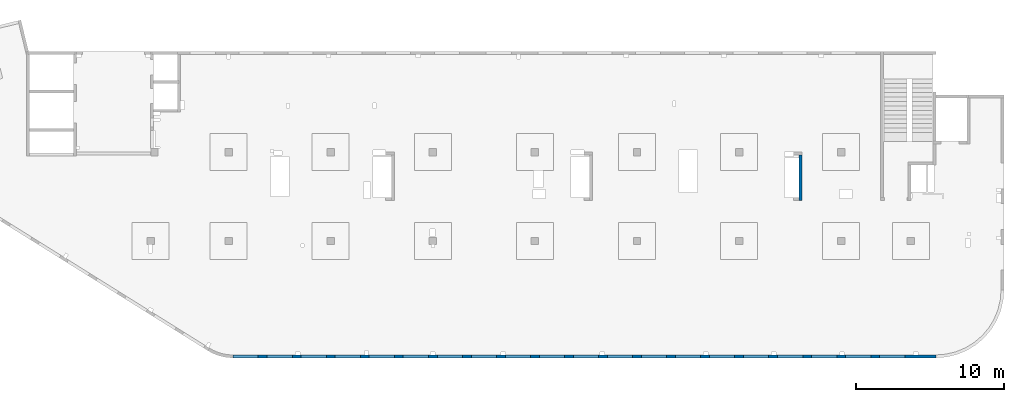
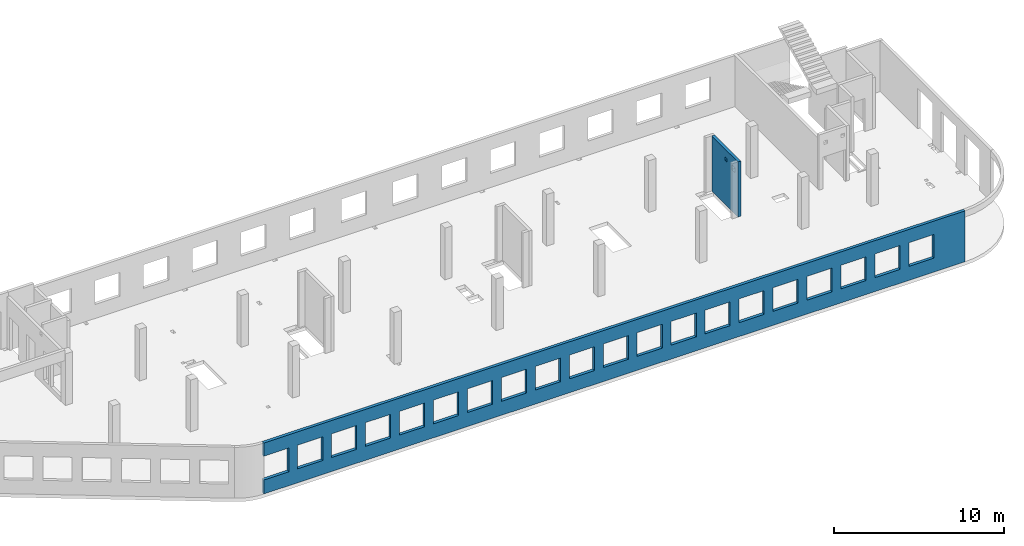
# One storey, part 6 of 7: 2 walls, 22 openings.
"""IFC4 building model written with IfcOpenShell, lengths in millimetres."""

from ifc_helpers import new_model, entity, si_unit, converted_unit, derived_unit, direction, frame, origin, place, context, subcontext, project, spatial, indexed_curve, outline, extrude, polygons, material, type_object, element, save


model = new_model("IFC4")

# Units and contexts
model_context = context("Model", 3, precision=0.01, world=origin(), true_north=direction((6.12303176911189e-17, 1.0)))
plan_context = context("Plan", 3, precision=0.01, world=origin(), true_north=direction((6.12303176911189e-17, 1.0)))
body_context = subcontext(model_context, "Body", "Model", "MODEL_VIEW")
ifc_project = project(units=[si_unit("LENGTHUNIT", "METRE", prefix="MILLI"), si_unit("AREAUNIT", "SQUARE_METRE"), si_unit("VOLUMEUNIT", "CUBIC_METRE"), converted_unit("PLANEANGLEUNIT", "DEGREE", entity("IfcRatioMeasure", 0.0174532925199433), si_unit("PLANEANGLEUNIT", "RADIAN"), dimensions=[0, 0, 0, 0, 0, 0, 0]), si_unit("MASSUNIT", "GRAM", prefix="KILO"), derived_unit("MASSDENSITYUNIT", [(si_unit("MASSUNIT", "GRAM", prefix="KILO"), 1), (si_unit("LENGTHUNIT", "METRE"), -3)]), derived_unit("MOMENTOFINERTIAUNIT", [(si_unit("LENGTHUNIT", "METRE"), 4)]), si_unit("TIMEUNIT", "SECOND"), si_unit("FREQUENCYUNIT", "HERTZ"), si_unit("THERMODYNAMICTEMPERATUREUNIT", "DEGREE_CELSIUS"), derived_unit("THERMALTRANSMITTANCEUNIT", [(si_unit("MASSUNIT", "GRAM", prefix="KILO"), 1), (si_unit("THERMODYNAMICTEMPERATUREUNIT", "KELVIN"), -1), (si_unit("TIMEUNIT", "SECOND"), -3)]), derived_unit("VOLUMETRICFLOWRATEUNIT", [(si_unit("LENGTHUNIT", "METRE"), 3), (si_unit("TIMEUNIT", "SECOND"), -1)]), derived_unit("MASSFLOWRATEUNIT", [(si_unit("MASSUNIT", "GRAM", prefix="KILO"), 1), (si_unit("TIMEUNIT", "SECOND"), -1)]), derived_unit("ROTATIONALFREQUENCYUNIT", [(si_unit("TIMEUNIT", "SECOND"), -1)]), si_unit("ELECTRICCURRENTUNIT", "AMPERE"), si_unit("ELECTRICVOLTAGEUNIT", "VOLT"), si_unit("POWERUNIT", "WATT"), si_unit("FORCEUNIT", "NEWTON", prefix="KILO"), si_unit("ILLUMINANCEUNIT", "LUX"), si_unit("LUMINOUSFLUXUNIT", "LUMEN"), si_unit("LUMINOUSINTENSITYUNIT", "CANDELA"), derived_unit("USERDEFINED", [(si_unit("MASSUNIT", "GRAM", prefix="KILO"), -1), (si_unit("LENGTHUNIT", "METRE"), -2), (si_unit("TIMEUNIT", "SECOND"), 3), (si_unit("LUMINOUSFLUXUNIT", "LUMEN"), 1)]), derived_unit("LINEARVELOCITYUNIT", [(si_unit("LENGTHUNIT", "METRE"), 1), (si_unit("TIMEUNIT", "SECOND"), -1)]), si_unit("PRESSUREUNIT", "PASCAL"), derived_unit("USERDEFINED", [(si_unit("LENGTHUNIT", "METRE"), -2), (si_unit("MASSUNIT", "GRAM", prefix="KILO"), 1), (si_unit("TIMEUNIT", "SECOND"), -2)]), derived_unit("LINEARFORCEUNIT", [(si_unit("MASSUNIT", "GRAM", prefix="KILO"), 1), (si_unit("LENGTHUNIT", "METRE"), 1), (si_unit("TIMEUNIT", "SECOND"), -2), (si_unit("LENGTHUNIT", "METRE"), -1)]), derived_unit("PLANARFORCEUNIT", [(si_unit("MASSUNIT", "GRAM", prefix="KILO"), 1), (si_unit("LENGTHUNIT", "METRE"), 1), (si_unit("TIMEUNIT", "SECOND"), -2), (si_unit("LENGTHUNIT", "METRE"), -2)])], contexts=[model_context, plan_context])

# Site, building, storey
site_placement = place(None, origin())
site = spatial("IfcSite", under=ifc_project, at=site_placement, CompositionType="ELEMENT")
building_placement = place(site_placement, origin())
building = spatial("IfcBuilding", under=site, at=building_placement, CompositionType="ELEMENT")
storey_placement = place(building_placement, frame((0.0, 0.0, 12000.0)))
storey = spatial("IfcBuildingStorey", under=building, at=storey_placement, CompositionType="ELEMENT", Elevation=12000.0)

# Wall, openings
ifc_material = material()
wall_type = type_object("IfcWallType", PredefinedType="STANDARD")
wall_1_placement = place(storey_placement, frame((68970.0002685547, -99.9999557734324, -150.0), z_axis=(0.0, 0.0, 1.0), x_axis=(-1.0, 0.0, 0.0)))
wall_1 = element("IfcWall", 1, at=wall_1_placement, inside=storey, type_object=wall_type, material=ifc_material, PredefinedType="NOTDEFINED", context=body_context, shape_type="Tessellation", body=[
    polygons([(8.66293717728731e-12, -100.0, 0.0), (47500.0, -100.0, 0.0), (47500.0, -100.0, 1000.00000000001), (45800.0, -100.000000000321, 1000.00000000001), (45800.0, -100.000000000321, 2699.99999999999), (47500.0, -100.0, 2699.99999999999), (47500.0, -100.0, 3650.0), (8.66293717728731e-12, -100.0, 3650.0), (1.42900165493394e-19, -100.0, 3200.0), (43500.0, -100.000000000321, 2700.0), (45200.0, -100.000000000321, 2700.0), (45200.0, -100.000000000321, 1000.00000000001), (43500.0, -100.000000000321, 1000.00000000001), (41200.0, -100.000000000321, 2700.0), (42900.0, -100.000000000321, 2700.0), (42900.0, -100.000000000321, 1000.00000000001), (41200.0, -100.000000000321, 1000.00000000001), (38900.0, -100.000000000321, 2700.0), (40600.0, -100.000000000321, 2700.0), (40600.0, -100.000000000321, 1000.00000000001), (38900.0, -100.000000000321, 1000.00000000001), (36600.0, -100.000000000321, 2700.0), (38300.0, -100.000000000321, 2700.0), (38300.0, -100.000000000321, 1000.00000000001), (36600.0, -100.000000000321, 1000.00000000001), (34300.0, -100.000000000321, 2700.0), (36000.0, -100.000000000321, 2700.0), (36000.0, -100.000000000321, 1000.00000000001), (34300.0, -100.000000000321, 1000.00000000001), (32000.0, -100.000000000321, 2700.0), (33700.0, -100.000000000321, 2700.0), (33700.0, -100.000000000321, 1000.00000000001), (32000.0, -100.000000000321, 1000.00000000001), (29700.0, -100.000000000321, 2700.0), (31400.0, -100.000000000321, 2700.0), (31400.0, -100.000000000321, 1000.00000000001), (29700.0, -100.000000000321, 1000.00000000001), (27400.0, -100.000000000321, 2700.0), (29100.0, -100.000000000321, 2700.0), (29100.0, -100.000000000321, 1000.00000000001), (27400.0, -100.000000000321, 1000.00000000001), (25100.0, -100.000000000321, 2700.0), (26800.0, -100.000000000321, 2700.0), (26800.0, -100.000000000321, 1000.00000000001), (25100.0, -100.000000000321, 1000.00000000001), (22800.0, -100.000000000321, 2700.0), (24500.0, -100.000000000321, 2700.0), (24500.0, -100.000000000321, 1000.00000000001), (22800.0, -100.000000000321, 1000.00000000001), (20500.0, -100.000000000321, 2700.0), (22200.0, -100.000000000321, 2700.0), (22200.0, -100.000000000321, 1000.00000000001), (20500.0, -100.000000000321, 1000.00000000001), (18200.0, -100.000000000321, 2700.0), (19900.0, -100.000000000321, 2700.0), (19900.0, -100.000000000321, 1000.00000000001), (18200.0, -100.000000000321, 1000.00000000001), (15900.0, -100.000000000321, 2700.0), (17600.0, -100.000000000321, 2700.0), (17600.0, -100.000000000321, 1000.00000000001), (15900.0, -100.000000000321, 1000.00000000001), (13600.0, -100.000000000321, 2700.0), (15300.0, -100.000000000321, 2700.0), (15300.0, -100.000000000321, 1000.00000000001), (13600.0, -100.000000000321, 1000.00000000001), (11300.0, -100.000000000321, 2700.0), (13000.0, -100.000000000321, 2700.0), (13000.0, -100.000000000321, 1000.00000000001), (11300.0, -100.000000000321, 1000.00000000001), (8999.99999999998, -100.000000000321, 2700.0), (10700.0, -100.000000000321, 2700.0), (10700.0, -100.000000000321, 1000.00000000001), (8999.99999999998, -100.000000000321, 1000.00000000001), (6699.99999999998, -100.000000000321, 2700.0), (8399.99999999997, -100.000000000321, 2700.0), (8399.99999999997, -100.000000000321, 1000.00000000001), (6699.99999999998, -100.000000000321, 1000.00000000001), (4399.99999999998, -100.000000000321, 2700.0), (6099.99999999997, -100.000000000321, 2700.0), (6099.99999999997, -100.000000000321, 1000.00000000001), (4399.99999999998, -100.000000000321, 1000.00000000001), (2099.99999999998, -100.000000000321, 2700.0), (3799.99999999998, -100.000000000321, 2700.0), (3799.99999999998, -100.000000000321, 1000.00000000001), (2099.99999999998, -100.000000000321, 1000.00000000001), (47500.0, 100.0, 0.0), (8.01671852045731e-12, 100.0, 0.0), (-6.46218513929826e-13, 100.0, 3200.0), (8.01671852045731e-12, 100.0, 3650.0), (47500.0, 100.0, 3650.0), (47500.0, 100.0, 2699.99999999999), (45800.0, 100.0, 2699.99999999999), (45800.0, 100.0, 1000.00000000001), (47500.0, 100.0, 1000.00000000001), (45200.0, 100.0, 2699.99999999999), (43500.0, 100.0, 2699.99999999999), (43500.0, 100.0, 1000.00000000001), (45200.0, 100.0, 1000.00000000001), (42900.0, 100.0, 2699.99999999999), (41200.0, 100.0, 2699.99999999999), (41200.0, 100.0, 1000.00000000001), (42900.0, 100.0, 1000.00000000001), (40600.0, 100.0, 2699.99999999999), (38900.0, 100.0, 2699.99999999999), (38900.0, 100.0, 1000.00000000001), (40600.0, 100.0, 1000.00000000001), (38300.0, 100.0, 2699.99999999999), (36600.0, 100.0, 2699.99999999999), (36600.0, 100.0, 1000.00000000001), (38300.0, 100.0, 1000.00000000001), (36000.0, 100.0, 2699.99999999999), (34300.0, 100.0, 2699.99999999999), (34300.0, 100.0, 1000.00000000001), (36000.0, 100.0, 1000.00000000001), (33700.0, 100.0, 2699.99999999999), (32000.0, 100.0, 2699.99999999999), (32000.0, 100.0, 1000.00000000001), (33700.0, 100.0, 1000.00000000001), (31400.0, 100.0, 2699.99999999999), (29700.0, 100.0, 2699.99999999999), (29700.0, 100.0, 1000.00000000001), (31400.0, 100.0, 1000.00000000001), (29100.0, 100.0, 2699.99999999999), (27400.0, 100.0, 2699.99999999999), (27400.0, 100.0, 1000.00000000001), (29100.0, 100.0, 1000.00000000001), (26800.0, 100.0, 2699.99999999999), (25100.0, 100.0, 2699.99999999999), (25100.0, 100.0, 1000.00000000001), (26800.0, 100.0, 1000.00000000001), (24500.0, 100.0, 2699.99999999999), (22800.0, 100.0, 2699.99999999999), (22800.0, 100.0, 1000.00000000001), (24500.0, 100.0, 1000.00000000001), (22200.0, 100.0, 2699.99999999999), (20500.0, 100.0, 2699.99999999999), (20500.0, 100.0, 1000.00000000001), (22200.0, 100.0, 1000.00000000001), (19900.0, 100.0, 2699.99999999999), (18200.0, 100.0, 2699.99999999999), (18200.0, 100.0, 1000.00000000001), (19900.0, 100.0, 1000.00000000001), (17600.0, 100.0, 2699.99999999999), (15900.0, 100.0, 2699.99999999999), (15900.0, 100.0, 1000.00000000001), (17600.0, 100.0, 1000.00000000001), (15300.0, 100.0, 2699.99999999999), (13600.0, 100.0, 2699.99999999999), (13600.0, 100.0, 1000.00000000001), (15300.0, 100.0, 1000.00000000001), (13000.0, 100.0, 2699.99999999999), (11300.0, 100.0, 2699.99999999999), (11300.0, 100.0, 1000.00000000001), (13000.0, 100.0, 1000.00000000001), (10700.0, 100.0, 2699.99999999999), (8999.99999999998, 100.0, 2699.99999999999), (8999.99999999998, 100.0, 1000.00000000001), (10700.0, 100.0, 1000.00000000001), (8399.99999999997, 100.0, 2699.99999999999), (6699.99999999997, 100.0, 2699.99999999999), (6699.99999999997, 100.0, 1000.00000000001), (8399.99999999997, 100.0, 1000.00000000001), (6099.99999999997, 100.0, 2699.99999999999), (4399.99999999998, 100.0, 2699.99999999999), (4399.99999999998, 100.0, 1000.00000000001), (6099.99999999997, 100.0, 1000.00000000001), (3799.99999999998, 100.0, 2699.99999999999), (2099.99999999998, 100.0, 2699.99999999999), (2099.99999999998, 100.0, 1000.00000000001), (3799.99999999998, 100.0, 1000.00000000001)], [[[1, 2, 3, 4, 5, 6, 7, 8, 9], [10, 11, 12, 13], [14, 15, 16, 17], [18, 19, 20, 21], [22, 23, 24, 25], [26, 27, 28, 29], [30, 31, 32, 33], [34, 35, 36, 37], [38, 39, 40, 41], [42, 43, 44, 45], [46, 47, 48, 49], [50, 51, 52, 53], [54, 55, 56, 57], [58, 59, 60, 61], [62, 63, 64, 65], [66, 67, 68, 69], [70, 71, 72, 73], [74, 75, 76, 77], [78, 79, 80, 81], [82, 83, 84, 85]], [[86, 87, 88, 89, 90, 91, 92, 93, 94], [95, 96, 97, 98], [99, 100, 101, 102], [103, 104, 105, 106], [107, 108, 109, 110], [111, 112, 113, 114], [115, 116, 117, 118], [119, 120, 121, 122], [123, 124, 125, 126], [127, 128, 129, 130], [131, 132, 133, 134], [135, 136, 137, 138], [139, 140, 141, 142], [143, 144, 145, 146], [147, 148, 149, 150], [151, 152, 153, 154], [155, 156, 157, 158], [159, 160, 161, 162], [163, 164, 165, 166], [167, 168, 169, 170]], [[2, 1, 87, 86]], [[2, 86, 94, 3]], [[8, 7, 90, 89]], [[1, 9, 8, 89, 88, 87]], [[5, 92, 91, 6]], [[93, 4, 3, 94]], [[92, 5, 4, 93]], [[11, 10, 96, 95]], [[11, 95, 98, 12]], [[12, 98, 97, 13]], [[96, 10, 13, 97]], [[15, 14, 100, 99]], [[15, 99, 102, 16]], [[16, 102, 101, 17]], [[100, 14, 17, 101]], [[19, 18, 104, 103]], [[19, 103, 106, 20]], [[20, 106, 105, 21]], [[104, 18, 21, 105]], [[23, 22, 108, 107]], [[23, 107, 110, 24]], [[24, 110, 109, 25]], [[108, 22, 25, 109]], [[27, 26, 112, 111]], [[27, 111, 114, 28]], [[28, 114, 113, 29]], [[112, 26, 29, 113]], [[31, 30, 116, 115]], [[31, 115, 118, 32]], [[32, 118, 117, 33]], [[116, 30, 33, 117]], [[35, 34, 120, 119]], [[35, 119, 122, 36]], [[36, 122, 121, 37]], [[120, 34, 37, 121]], [[39, 38, 124, 123]], [[39, 123, 126, 40]], [[40, 126, 125, 41]], [[124, 38, 41, 125]], [[43, 42, 128, 127]], [[43, 127, 130, 44]], [[44, 130, 129, 45]], [[128, 42, 45, 129]], [[47, 46, 132, 131]], [[47, 131, 134, 48]], [[48, 134, 133, 49]], [[132, 46, 49, 133]], [[51, 50, 136, 135]], [[51, 135, 138, 52]], [[52, 138, 137, 53]], [[136, 50, 53, 137]], [[55, 54, 140, 139]], [[55, 139, 142, 56]], [[56, 142, 141, 57]], [[140, 54, 57, 141]], [[59, 58, 144, 143]], [[59, 143, 146, 60]], [[60, 146, 145, 61]], [[144, 58, 61, 145]], [[63, 62, 148, 147]], [[63, 147, 150, 64]], [[64, 150, 149, 65]], [[148, 62, 65, 149]], [[67, 66, 152, 151]], [[67, 151, 154, 68]], [[68, 154, 153, 69]], [[152, 66, 69, 153]], [[71, 70, 156, 155]], [[71, 155, 158, 72]], [[72, 158, 157, 73]], [[156, 70, 73, 157]], [[75, 74, 160, 159]], [[75, 159, 162, 76]], [[76, 162, 161, 77]], [[160, 74, 77, 161]], [[79, 78, 164, 163]], [[79, 163, 166, 80]], [[80, 166, 165, 81]], [[164, 78, 81, 165]], [[83, 82, 168, 167]], [[83, 167, 170, 84]], [[84, 170, 169, 85]], [[168, 82, 85, 169]], [[90, 7, 6, 91]]], closed=True),
])
opening_1_placement = place(wall_1_placement, frame((68970.0002685547, -99.9999557734324, 150.0), z_axis=(0.0, 0.0, 1.0), x_axis=(-1.0, 0.0, 0.0)))
element("IfcOpeningElement", 2, at=opening_1_placement, cuts=wall_1, PredefinedType="OPENING", context=body_context, shape_type="SweptSolid", body=[
    extrude(outline(indexed_curve([(-850.000000000002, -849.999999999995), (849.999999999997, -849.999999999995), (849.999999999997, 849.999999999993), (-850.000000000002, 849.999999999993), (-850.000000000002, -849.999999999995)], self_intersect=False)), frame((22320.0002685547, 4.42276800359536e-05, 1700.0), z_axis=(0.0, -1.0, 0.0), x_axis=(-1.0, 0.0, 0.0)), (0.0, 0.0, 1.0), 200.000000000962),
])
opening_2_placement = place(wall_1_placement, frame((68970.0002685547, -99.9999557734324, 150.0), z_axis=(0.0, 0.0, 1.0), x_axis=(-1.0, 0.0, 0.0)))
element("IfcOpeningElement", 3, at=opening_2_placement, cuts=wall_1, PredefinedType="OPENING", context=body_context, shape_type="SweptSolid", body=[
    extrude(outline(indexed_curve([(-849.999999999997, -849.999999999995), (850.000000000006, -849.999999999995), (850.000000000006, 849.999999999993), (-849.999999999997, 849.999999999993), (-849.999999999997, -849.999999999995)], self_intersect=False)), frame((66020.0002685547, 4.4227538823312e-05, 1700.0), z_axis=(0.0, -1.0, 0.0), x_axis=(-1.0, 0.0, 0.0)), (0.0, 0.0, 1.0), 200.000000000962),
])
opening_3_placement = place(wall_1_placement, frame((68970.0002685547, -99.9999557734324, 150.0), z_axis=(0.0, 0.0, 1.0), x_axis=(-1.0, 0.0, 0.0)))
element("IfcOpeningElement", 4, at=opening_3_placement, cuts=wall_1, PredefinedType="OPENING", context=body_context, shape_type="SweptSolid", body=[
    extrude(outline(indexed_curve([(-849.999999999997, -849.999999999995), (850.000000000006, -849.999999999995), (850.000000000006, 849.999999999993), (-849.999999999997, 849.999999999993), (-849.999999999997, -849.999999999995)], self_intersect=False)), frame((63720.0002685547, 4.42275462680235e-05, 1700.0), z_axis=(0.0, -1.0, 0.0), x_axis=(-1.0, 0.0, 0.0)), (0.0, 0.0, 1.0), 200.000000000962),
])
opening_4_placement = place(wall_1_placement, frame((68970.0002685547, -99.9999557734324, 150.0), z_axis=(0.0, 0.0, 1.0), x_axis=(-1.0, 0.0, 0.0)))
element("IfcOpeningElement", 5, at=opening_4_placement, cuts=wall_1, PredefinedType="OPENING", context=body_context, shape_type="SweptSolid", body=[
    extrude(outline(indexed_curve([(-849.999999999997, -849.999999999995), (850.000000000006, -849.999999999995), (850.000000000006, 849.999999999993), (-849.999999999997, 849.999999999993), (-849.999999999997, -849.999999999995)], self_intersect=False)), frame((61420.0002685547, 4.42275536958152e-05, 1700.0), z_axis=(0.0, -1.0, 0.0), x_axis=(-1.0, 0.0, 0.0)), (0.0, 0.0, 1.0), 200.000000000962),
])
opening_5_placement = place(wall_1_placement, frame((68970.0002685547, -99.9999557734324, 150.0), z_axis=(0.0, 0.0, 1.0), x_axis=(-1.0, 0.0, 0.0)))
element("IfcOpeningElement", 6, at=opening_5_placement, cuts=wall_1, PredefinedType="OPENING", context=body_context, shape_type="SweptSolid", body=[
    extrude(outline(indexed_curve([(-849.999999999997, -849.999999999995), (850.000000000006, -849.999999999995), (850.000000000006, 849.999999999993), (-849.999999999997, 849.999999999993), (-849.999999999997, -849.999999999995)], self_intersect=False)), frame((59120.0002685547, 4.4227561123607e-05, 1700.0), z_axis=(0.0, -1.0, 0.0), x_axis=(-1.0, 0.0, 0.0)), (0.0, 0.0, 1.0), 200.000000000962),
])
opening_6_placement = place(wall_1_placement, frame((68970.0002685547, -99.9999557734324, 150.0), z_axis=(0.0, 0.0, 1.0), x_axis=(-1.0, 0.0, 0.0)))
element("IfcOpeningElement", 7, at=opening_6_placement, cuts=wall_1, PredefinedType="OPENING", context=body_context, shape_type="SweptSolid", body=[
    extrude(outline(indexed_curve([(-849.999999999997, -849.999999999995), (850.000000000006, -849.999999999995), (850.000000000006, 849.999999999993), (-849.999999999997, 849.999999999993), (-849.999999999997, -849.999999999995)], self_intersect=False)), frame((56820.0002685547, 4.42275685513987e-05, 1700.0), z_axis=(0.0, -1.0, 0.0), x_axis=(-1.0, 0.0, 0.0)), (0.0, 0.0, 1.0), 200.000000000962),
])
opening_7_placement = place(wall_1_placement, frame((68970.0002685547, -99.9999557734324, 150.0), z_axis=(0.0, 0.0, 1.0), x_axis=(-1.0, 0.0, 0.0)))
element("IfcOpeningElement", 8, at=opening_7_placement, cuts=wall_1, PredefinedType="OPENING", context=body_context, shape_type="SweptSolid", body=[
    extrude(outline(indexed_curve([(-849.999999999997, -849.999999999995), (850.000000000006, -849.999999999995), (850.000000000006, 849.999999999993), (-849.999999999997, 849.999999999993), (-849.999999999997, -849.999999999995)], self_intersect=False)), frame((54520.0002685547, 4.42275759791904e-05, 1700.0), z_axis=(0.0, -1.0, 0.0), x_axis=(-1.0, 0.0, 0.0)), (0.0, 0.0, 1.0), 200.000000000962),
])
opening_8_placement = place(wall_1_placement, frame((68970.0002685547, -99.9999557734324, 150.0), z_axis=(0.0, 0.0, 1.0), x_axis=(-1.0, 0.0, 0.0)))
element("IfcOpeningElement", 9, at=opening_8_placement, cuts=wall_1, PredefinedType="OPENING", context=body_context, shape_type="SweptSolid", body=[
    extrude(outline(indexed_curve([(-849.999999999997, -849.999999999995), (850.000000000006, -849.999999999995), (850.000000000006, 849.999999999993), (-849.999999999997, 849.999999999993), (-849.999999999997, -849.999999999995)], self_intersect=False)), frame((52220.0002685547, 4.42275834239019e-05, 1700.0), z_axis=(0.0, -1.0, 0.0), x_axis=(-1.0, 0.0, 0.0)), (0.0, 0.0, 1.0), 200.000000000962),
])
opening_9_placement = place(wall_1_placement, frame((68970.0002685547, -99.9999557734324, 150.0), z_axis=(0.0, 0.0, 1.0), x_axis=(-1.0, 0.0, 0.0)))
element("IfcOpeningElement", 10, at=opening_9_placement, cuts=wall_1, PredefinedType="OPENING", context=body_context, shape_type="SweptSolid", body=[
    extrude(outline(indexed_curve([(-849.999999999997, -849.999999999995), (850.000000000006, -849.999999999995), (850.000000000006, 849.999999999993), (-849.999999999997, 849.999999999993), (-849.999999999997, -849.999999999995)], self_intersect=False)), frame((49920.0002685547, 4.42275908516936e-05, 1700.0), z_axis=(0.0, -1.0, 0.0), x_axis=(-1.0, 0.0, 0.0)), (0.0, 0.0, 1.0), 200.000000000962),
])
opening_10_placement = place(wall_1_placement, frame((68970.0002685547, -99.9999557734324, 150.0), z_axis=(0.0, 0.0, 1.0), x_axis=(-1.0, 0.0, 0.0)))
element("IfcOpeningElement", 11, at=opening_10_placement, cuts=wall_1, PredefinedType="OPENING", context=body_context, shape_type="SweptSolid", body=[
    extrude(outline(indexed_curve([(-849.999999999997, -849.999999999995), (850.000000000006, -849.999999999995), (850.000000000006, 849.999999999993), (-849.999999999997, 849.999999999993), (-849.999999999997, -849.999999999995)], self_intersect=False)), frame((47620.0002685547, 4.42275982794853e-05, 1700.0), z_axis=(0.0, -1.0, 0.0), x_axis=(-1.0, 0.0, 0.0)), (0.0, 0.0, 1.0), 200.000000000962),
])
opening_11_placement = place(wall_1_placement, frame((68970.0002685547, -99.9999557734324, 150.0), z_axis=(0.0, 0.0, 1.0), x_axis=(-1.0, 0.0, 0.0)))
element("IfcOpeningElement", 12, at=opening_11_placement, cuts=wall_1, PredefinedType="OPENING", context=body_context, shape_type="SweptSolid", body=[
    extrude(outline(indexed_curve([(-849.999999999997, -849.999999999995), (850.000000000006, -849.999999999995), (850.000000000006, 849.999999999993), (-849.999999999997, 849.999999999993), (-849.999999999997, -849.999999999995)], self_intersect=False)), frame((45320.0002685547, 4.4227605707277e-05, 1700.0), z_axis=(0.0, -1.0, 0.0), x_axis=(-1.0, 0.0, 0.0)), (0.0, 0.0, 1.0), 200.000000000962),
])
opening_12_placement = place(wall_1_placement, frame((68970.0002685547, -99.9999557734324, 150.0), z_axis=(0.0, 0.0, 1.0), x_axis=(-1.0, 0.0, 0.0)))
element("IfcOpeningElement", 13, at=opening_12_placement, cuts=wall_1, PredefinedType="OPENING", context=body_context, shape_type="SweptSolid", body=[
    extrude(outline(indexed_curve([(-849.999999999997, -849.999999999995), (850.000000000006, -849.999999999995), (850.000000000006, 849.999999999993), (-849.999999999997, 849.999999999993), (-849.999999999997, -849.999999999995)], self_intersect=False)), frame((43020.0002685547, 4.42276131519886e-05, 1700.0), z_axis=(0.0, -1.0, 0.0), x_axis=(-1.0, 0.0, 0.0)), (0.0, 0.0, 1.0), 200.000000000962),
])
opening_13_placement = place(wall_1_placement, frame((68970.0002685547, -99.9999557734324, 150.0), z_axis=(0.0, 0.0, 1.0), x_axis=(-1.0, 0.0, 0.0)))
element("IfcOpeningElement", 14, at=opening_13_placement, cuts=wall_1, PredefinedType="OPENING", context=body_context, shape_type="SweptSolid", body=[
    extrude(outline(indexed_curve([(-849.999999999997, -849.999999999995), (850.000000000006, -849.999999999995), (850.000000000006, 849.999999999993), (-849.999999999997, 849.999999999993), (-849.999999999997, -849.999999999995)], self_intersect=False)), frame((40720.0002685547, 4.42276205797803e-05, 1700.0), z_axis=(0.0, -1.0, 0.0), x_axis=(-1.0, 0.0, 0.0)), (0.0, 0.0, 1.0), 200.000000000962),
])
opening_14_placement = place(wall_1_placement, frame((68970.0002685547, -99.9999557734324, 150.0), z_axis=(0.0, 0.0, 1.0), x_axis=(-1.0, 0.0, 0.0)))
element("IfcOpeningElement", 15, at=opening_14_placement, cuts=wall_1, PredefinedType="OPENING", context=body_context, shape_type="SweptSolid", body=[
    extrude(outline(indexed_curve([(-849.999999999997, -849.999999999995), (850.000000000002, -849.999999999995), (850.000000000002, 849.999999999993), (-849.999999999997, 849.999999999993), (-849.999999999997, -849.999999999995)], self_intersect=False)), frame((38420.0002685547, 4.4227628007572e-05, 1700.0), z_axis=(0.0, -1.0, 0.0), x_axis=(-1.0, 0.0, 0.0)), (0.0, 0.0, 1.0), 200.000000000962),
])
opening_15_placement = place(wall_1_placement, frame((68970.0002685547, -99.9999557734324, 150.0), z_axis=(0.0, 0.0, 1.0), x_axis=(-1.0, 0.0, 0.0)))
element("IfcOpeningElement", 16, at=opening_15_placement, cuts=wall_1, PredefinedType="OPENING", context=body_context, shape_type="SweptSolid", body=[
    extrude(outline(indexed_curve([(-849.999999999997, -849.999999999995), (850.000000000002, -849.999999999995), (850.000000000002, 849.999999999993), (-849.999999999997, 849.999999999993), (-849.999999999997, -849.999999999995)], self_intersect=False)), frame((36120.0002685547, 4.42276354353637e-05, 1700.0), z_axis=(0.0, -1.0, 0.0), x_axis=(-1.0, 0.0, 0.0)), (0.0, 0.0, 1.0), 200.000000000962),
])
opening_16_placement = place(wall_1_placement, frame((68970.0002685547, -99.9999557734324, 150.0), z_axis=(0.0, 0.0, 1.0), x_axis=(-1.0, 0.0, 0.0)))
element("IfcOpeningElement", 17, at=opening_16_placement, cuts=wall_1, PredefinedType="OPENING", context=body_context, shape_type="SweptSolid", body=[
    extrude(outline(indexed_curve([(-849.999999999997, -849.999999999995), (850.000000000002, -849.999999999995), (850.000000000002, 849.999999999993), (-849.999999999997, 849.999999999993), (-849.999999999997, -849.999999999995)], self_intersect=False)), frame((33820.0002685547, 4.42276428631554e-05, 1700.0), z_axis=(0.0, -1.0, 0.0), x_axis=(-1.0, 0.0, 0.0)), (0.0, 0.0, 1.0), 200.000000000962),
])
opening_17_placement = place(wall_1_placement, frame((68970.0002685547, -99.9999557734324, 150.0), z_axis=(0.0, 0.0, 1.0), x_axis=(-1.0, 0.0, 0.0)))
element("IfcOpeningElement", 18, at=opening_17_placement, cuts=wall_1, PredefinedType="OPENING", context=body_context, shape_type="SweptSolid", body=[
    extrude(outline(indexed_curve([(-849.999999999997, -849.999999999995), (850.000000000002, -849.999999999995), (850.000000000002, 849.999999999993), (-849.999999999997, 849.999999999993), (-849.999999999997, -849.999999999995)], self_intersect=False)), frame((31520.0002685547, 4.42276503078669e-05, 1700.0), z_axis=(0.0, -1.0, 0.0), x_axis=(-1.0, 0.0, 0.0)), (0.0, 0.0, 1.0), 200.000000000962),
])
opening_18_placement = place(wall_1_placement, frame((68970.0002685547, -99.9999557734324, 150.0), z_axis=(0.0, 0.0, 1.0), x_axis=(-1.0, 0.0, 0.0)))
element("IfcOpeningElement", 19, at=opening_18_placement, cuts=wall_1, PredefinedType="OPENING", context=body_context, shape_type="SweptSolid", body=[
    extrude(outline(indexed_curve([(-850.000000000002, -849.999999999995), (849.999999999997, -849.999999999995), (849.999999999997, 849.999999999993), (-850.000000000002, 849.999999999993), (-850.000000000002, -849.999999999995)], self_intersect=False)), frame((29220.0002685547, 4.42276577356586e-05, 1700.0), z_axis=(0.0, -1.0, 0.0), x_axis=(-1.0, 0.0, 0.0)), (0.0, 0.0, 1.0), 200.000000000962),
])
opening_19_placement = place(wall_1_placement, frame((68970.0002685547, -99.9999557734324, 150.0), z_axis=(0.0, 0.0, 1.0), x_axis=(-1.0, 0.0, 0.0)))
element("IfcOpeningElement", 20, at=opening_19_placement, cuts=wall_1, PredefinedType="OPENING", context=body_context, shape_type="SweptSolid", body=[
    extrude(outline(indexed_curve([(-850.000000000002, -849.999999999995), (849.999999999997, -849.999999999995), (849.999999999997, 849.999999999993), (-850.000000000002, 849.999999999993), (-850.000000000002, -849.999999999995)], self_intersect=False)), frame((26920.0002685547, 4.42276651634504e-05, 1700.0), z_axis=(0.0, -1.0, 0.0), x_axis=(-1.0, 0.0, 0.0)), (0.0, 0.0, 1.0), 200.000000000962),
])
opening_20_placement = place(wall_1_placement, frame((68970.0002685547, -99.9999557734324, 150.0), z_axis=(0.0, 0.0, 1.0), x_axis=(-1.0, 0.0, 0.0)))
element("IfcOpeningElement", 21, at=opening_20_placement, cuts=wall_1, PredefinedType="OPENING", context=body_context, shape_type="SweptSolid", body=[
    extrude(outline(indexed_curve([(-850.000000000002, -849.999999999995), (849.999999999997, -849.999999999995), (849.999999999997, 849.999999999993), (-850.000000000002, 849.999999999993), (-850.000000000002, -849.999999999995)], self_intersect=False)), frame((24620.0002685547, 4.42276725912421e-05, 1700.0), z_axis=(0.0, -1.0, 0.0), x_axis=(-1.0, 0.0, 0.0)), (0.0, 0.0, 1.0), 200.000000000962),
])

wall_2_placement = place(storey_placement, frame((59830.0002685547, 13499.9992263555, -150.0), z_axis=(0.0, 0.0, 1.0), x_axis=(0.0, -1.0, 0.0)))
wall_2 = element("IfcWall", 22, at=wall_2_placement, inside=storey, type_object=wall_type, material=ifc_material, PredefinedType="NOTDEFINED", context=body_context, shape_type="Tessellation", body=[
    polygons([(-2.16573425859679e-12, -99.999999999987, 0.0), (2875.00000000001, -99.9999999999967, 0.0), (3075.00000000001, -99.9999999999962, 0.0), (3075.00000000001, -99.9999999999962, 3950.0), (2875.00000000001, -99.9999999999967, 3950.0), (-2.16573425859679e-12, -99.999999999987, 3950.0), (1560.00000000001, -100.000000000009, 3400.0), (1810.00000000001, -100.000000000008, 3400.0), (1810.00000000001, -100.000000000008, 3150.00000000001), (1560.00000000001, -100.000000000009, 3150.00000000001), (2360.00000000001, -100.000000000007, 3330.0), (2710.00000000001, -100.000000000006, 3330.0), (2710.00000000001, -100.000000000006, 2980.00000000001), (2360.00000000001, -100.000000000007, 2980.00000000001), (-2.16573425859679e-12, 100.000000000002, 0.0), (-2.16573425859679e-12, 100.000000000002, 3950.0), (3075.00000000001, 99.999999999993, 3950.0), (3075.00000000001, 99.999999999993, 0.0), (1810.00000000001, 100.000000000319, 3400.0), (1560.00000000001, 100.000000000318, 3400.0), (1560.00000000001, 100.000000000318, 3150.00000000001), (1810.00000000001, 100.000000000319, 3150.00000000001), (2710.00000000001, 100.000000000321, 3330.0), (2360.00000000001, 100.00000000032, 3330.0), (2360.00000000001, 100.00000000032, 2980.00000000001), (2710.00000000001, 100.000000000321, 2980.00000000001)], [[[1, 2, 3, 4, 5, 6], [7, 8, 9, 10], [11, 12, 13, 14]], [[15, 16, 17, 18], [19, 20, 21, 22], [23, 24, 25, 26]], [[3, 2, 1, 15, 18]], [[6, 5, 4, 17, 16]], [[1, 6, 16, 15]], [[4, 3, 18, 17]], [[20, 19, 8, 7]], [[20, 7, 10, 21]], [[21, 10, 9, 22]], [[8, 19, 22, 9]], [[24, 23, 12, 11]], [[24, 11, 14, 25]], [[25, 14, 13, 26]], [[12, 23, 26, 13]]], closed=True),
])
opening_21_placement = place(wall_2_placement, frame((13499.9992263555, -59830.0002685547, 150.0), z_axis=(0.0, 0.0, 1.0), x_axis=(0.0, 1.0, 0.0)))
element("IfcOpeningElement", 23, at=opening_21_placement, cuts=wall_2, PredefinedType="OPENING", context=body_context, shape_type="SweptSolid", body=[
    extrude(outline(indexed_curve([(-174.999999999993, -174.999999999999), (174.999999999993, -174.999999999999), (174.999999999993, 175.000000000001), (-174.999999999993, 175.000000000001), (-174.999999999993, -174.999999999999)], self_intersect=False)), frame((59730.0002685547, 10964.9992263555, 3005.0), z_axis=(1.0, 0.0, 0.0), x_axis=(0.0, 0.0, -1.0)), (0.0, 0.0, 1.0), 200.000000000968),
])
opening_22_placement = place(wall_2_placement, frame((13499.9992263555, -59830.0002685547, 150.0), z_axis=(0.0, 0.0, 1.0), x_axis=(0.0, 1.0, 0.0)))
element("IfcOpeningElement", 24, at=opening_22_placement, cuts=wall_2, PredefinedType="OPENING", context=body_context, shape_type="SweptSolid", body=[
    extrude(outline(indexed_curve([(-124.999999999991, -125.0), (124.999999999993, -125.0), (124.999999999993, 125.0), (-124.999999999991, 125.0), (-124.999999999991, -125.0)], self_intersect=False)), frame((59730.0002685547, 11814.9992263555, 3125.0), z_axis=(1.0, 0.0, 0.0), x_axis=(0.0, 0.0, -1.0)), (0.0, 0.0, 1.0), 200.000000000968),
])

save(model, "model.ifc")
